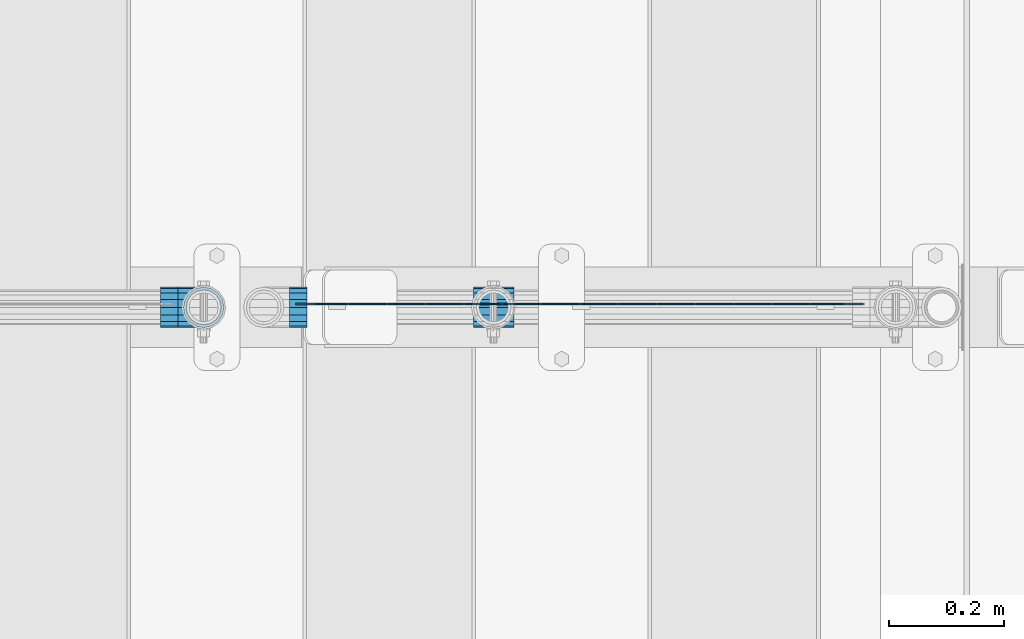
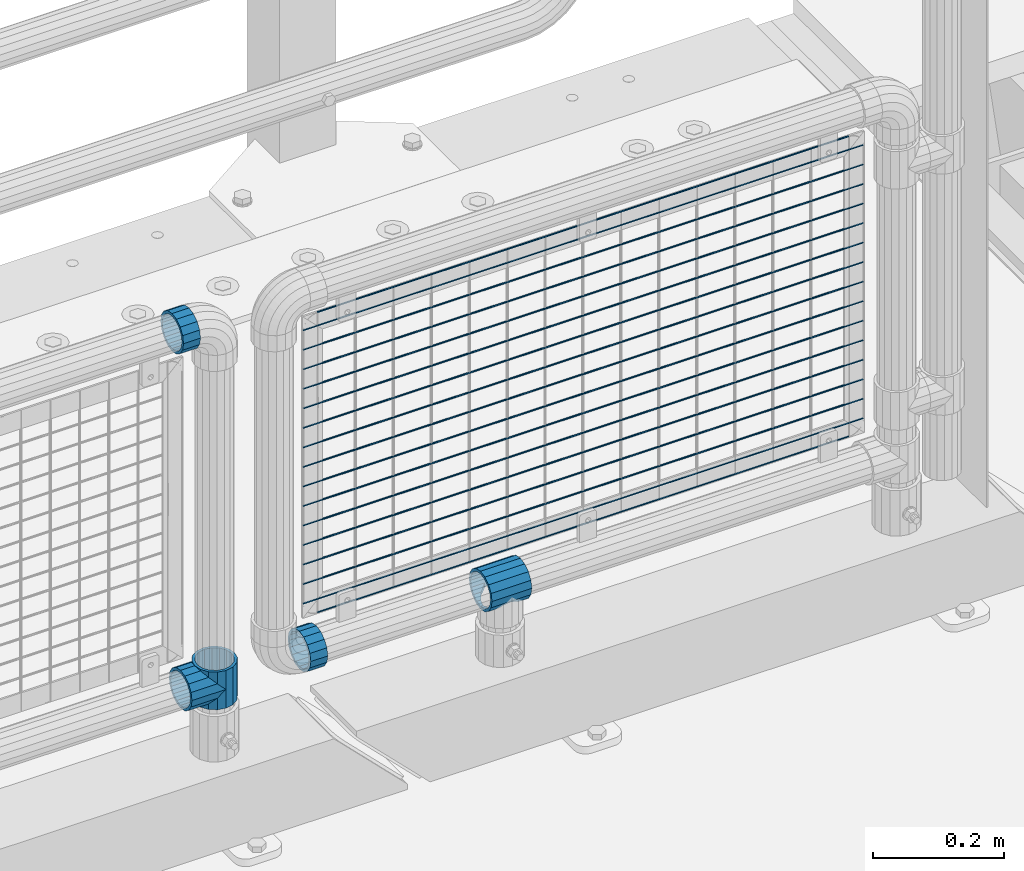
# One storey, part 157 of 240: 22 beams.
"""IFC2X3 building model written with IfcOpenShell, lengths in millimetres."""

from ifc_helpers import new_model, si_unit, frame, origin_with_axes, place, context, subcontext, project, spatial, faceted_brep, material, type_object, element, save


model = new_model("IFC2X3")

# Units and contexts
model_context = context("Model", 3, precision=1e-05, world=origin_with_axes())
body_context = subcontext(model_context, "Body", "Model", "MODEL_VIEW")
ifc_project = project(units=[si_unit("LENGTHUNIT", "METRE", prefix="MILLI"), si_unit("AREAUNIT", "SQUARE_METRE"), si_unit("VOLUMEUNIT", "CUBIC_METRE"), si_unit("MASSUNIT", "GRAM", prefix="KILO"), si_unit("TIMEUNIT", "SECOND"), si_unit("PLANEANGLEUNIT", "RADIAN"), si_unit("SOLIDANGLEUNIT", "STERADIAN"), si_unit("THERMODYNAMICTEMPERATUREUNIT", "DEGREE_CELSIUS"), si_unit("LUMINOUSINTENSITYUNIT", "LUMEN")], contexts=[model_context])

# Site, building, storey
site_placement = place(None, origin_with_axes())
site = spatial("IfcSite", under=ifc_project, at=site_placement, CompositionType="ELEMENT")
building_placement = place(site_placement, origin_with_axes())
building = spatial("IfcBuilding", under=site, at=building_placement, Name="Standard", CompositionType="ELEMENT")
storey_placement = place(building_placement, origin_with_axes())
storey = spatial("IfcBuildingStorey", under=building, at=storey_placement, Name="Undefined", CompositionType="ELEMENT", Elevation=0.0)

# Beams
ifc_material = material(Name="Misc_Undefined")
beam_type_1 = type_object("IfcBeamType", PredefinedType="NOTDEFINED")
beam_1_placement = place(storey_placement, frame((55146.46, 34664.5, 298.169999999999), z_axis=(0.0, 0.0, 1.0), x_axis=(1.0, 0.0, 0.0)))
element("IfcBeam", 1, at=beam_1_placement, inside=storey, type_object=beam_type_1, material=ifc_material, context=body_context, shape_type="Brep", body=[
    faceted_brep([(63.1897438117172, -11.6144421722784, -28.0397438117143), (63.1897438117172, -11.6144421722784, -32.8397438117245), (61.9623795176703, -13.4513226476338, -32.4743655677739), (56.6106908090114, -21.4606908090136, -27.1226768591223), (56.6106908090114, -21.4606908090136, -21.4606908090136), (51.5310424080006, -24.8548033587067, -24.8548033587067), (46.7644421722801, -28.0397438117143, -20.0882031229994), (46.7644421722801, -28.0397438117143, -11.6144421722784), (35.1499999999996, -30.3499999999985, -16.6306603983758), (35.1500000000015, -30.35, 0.0), (23.5355578277191, -28.0397438117143, -20.0882031229994), (23.5355578277191, -28.0397438117143, -11.6144421722784), (18.7689575919987, -24.8548033587067, -24.8548033587067), (13.6893091909879, -21.4606908090136, -27.1226768591223), (13.6893091909879, -21.4606908090136, -21.4606908090136), (8.33762048232455, -13.4513226476338, -32.4743655677739), (7.11025618828211, -11.6144421722784, -32.8397438117245), (7.11025618828211, -11.6144421722784, -28.0397438117143), (4.79999999999961, 0.0, -35.1500000000015), (4.79999999999961, 0.0, -30.3499999999985), (7.11025618828211, 11.6144421722784, -32.8397438117172), (7.11025618828211, 11.6144421722784, -28.0397438117143), (8.33762048232893, 13.4513226476338, -32.4743655677739), (13.6893091909879, 21.4606908090136, -27.1226768591077), (13.6893091909879, 21.4606908090136, -21.4606908090136), (18.7689575919921, 24.8548033587067, -24.8548033587067), (23.5355578277192, 28.0397438117143, -20.0882031229849), (23.5355578277192, 28.0397438117143, -11.6144421722784), (35.1499999999996, 30.3499999999985, -16.6306603983685), (35.1500000000015, 30.35, 0.0), (46.7644421722801, 28.0397438117143, -20.0882031229849), (46.7644421722801, 28.0397438117143, -11.6144421722784), (51.5310424079941, 24.8548033587067, -24.8548033587067), (56.6106908090114, 21.4606908090136, -27.1226768591077), (56.6106908090114, 21.4606908090136, -21.4606908090136), (61.9623795176703, 13.4513226476338, -32.4743655677739), (63.1897438117172, 11.6144421722784, -32.8397438117172), (63.1897438117172, 11.6144421722784, -28.0397438117143), (65.4999999999997, 0.0, -35.1500000000015), (65.4999999999997, 0.0, -30.3499999999985), (0.0, -21.4606908090136, -21.4606908090136), (0.0, -28.0397438117143, -11.6144421722784), (0.0, -11.6144421722784, -28.0397438117143), (0.0, 0.0, -30.3499999999985), (0.0, 11.6144421722784, -28.0397438117143), (0.0, 21.4606908090136, -21.4606908090136), (0.0, 28.0397438117143, -11.6144421722784), (0.0, 30.3499999999985, 0.0), (0.0, 32.4743655677739, -13.4513226476338), (0.0, 35.1500000000015, 0.0), (70.2999999999993, 35.1500000000015, 0.0), (70.2999999999993, 32.4743655677739, -13.4513226476338), (0.0, 32.4743655677739, 13.4513226476338), (70.2999999999993, 32.4743655677739, 13.4513226476338), (0.0, 24.8548033587067, 24.8548033587067), (70.2999999999993, 24.8548033587067, 24.8548033587067), (0.0, 13.4513226476338, 32.4743655677739), (70.2999999999993, 13.4513226476338, 32.4743655677739), (0.0, 0.0, 35.1500000000015), (70.2999999999993, 0.0, 35.1500000000015), (0.0, -13.4513226476338, 32.4743655677739), (70.2999999999993, -13.4513226476338, 32.4743655677739), (0.0, -24.8548033587067, 24.8548033587067), (70.2999999999993, -24.8548033587067, 24.8548033587067), (0.0, -32.4743655677739, 13.4513226476338), (70.2999999999993, -32.4743655677739, 13.4513226476338), (0.0, -35.1500000000015, 0.0), (70.2999999999993, -35.1500000000015, 0.0), (0.0, -32.4743655677739, -13.4513226476338), (70.2999999999993, -32.4743655677739, -13.4513226476338), (0.0, 24.8548033587067, -24.8548033587067), (0.0, 13.4513226476338, -32.4743655677739), (0.0, 0.0, -35.1500000000015), (0.0, -13.4513226476338, -32.4743655677739), (0.0, -24.8548033587067, -24.8548033587067), (0.0, 28.0397438117143, 11.6144421722784), (0.0, 21.4606908090136, 21.4606908090136), (0.0, 11.6144421722784, 28.0397438117143), (0.0, 0.0, 30.3499999999985), (0.0, -11.6144421722784, 28.0397438117143), (0.0, -21.4606908090136, 21.4606908090136), (0.0, -28.0397438117143, 11.6144421722784), (0.0, -30.3499999999985, 0.0), (70.2999999999993, -30.3499999999985, 0.0), (70.2999999999993, -28.0397438117143, -11.6144421722784), (70.2999999999993, -21.4606908090136, -21.4606908090136), (70.2999999999993, -11.6144421722784, -28.0397438117143), (70.2999999999993, 0.0, -30.3499999999985), (70.2999999999993, 21.4606908090136, -21.4606908090136), (70.2999999999993, 28.0397438117143, -11.6144421722784), (70.2999999999993, 11.6144421722784, -28.0397438117143), (70.2999999999993, 30.3499999999985, 0.0), (70.2999999999993, 28.0397438117143, 11.6144421722784), (70.2999999999993, 21.4606908090136, 21.4606908090136), (70.2999999999993, 11.6144421722784, 28.0397438117143), (70.2999999999993, 0.0, 30.3499999999985), (70.2999999999993, -11.6144421722784, 28.0397438117143), (70.2999999999993, -21.4606908090136, 21.4606908090136), (70.2999999999993, -28.0397438117143, 11.6144421722784), (70.2999999999993, -24.8548033587067, -24.8548033587067), (70.2999999999993, -13.4513226476338, -32.4743655677739), (70.2999999999993, 0.0, -35.1500000000015), (70.2999999999993, 13.4513226476338, -32.4743655677739), (70.2999999999993, 24.8548033587067, -24.8548033587067)], [[[0, 1, 2, 3, 4]], [[4, 3, 5, 6, 7]], [[7, 6, 8, 9]], [[9, 8, 10, 11]], [[11, 10, 12, 13, 14]], [[14, 13, 15, 16, 17]], [[17, 16, 18, 19]], [[19, 18, 20, 21]], [[21, 20, 22, 23, 24]], [[24, 23, 25, 26, 27]], [[27, 26, 28, 29]], [[29, 28, 30, 31]], [[31, 30, 32, 33, 34]], [[34, 33, 35, 36, 37]], [[37, 36, 38, 39]], [[39, 38, 1, 0]], [[40, 41, 11, 14]], [[42, 40, 14, 17]], [[43, 42, 17, 19]], [[44, 43, 19, 21]], [[45, 44, 21, 24]], [[46, 45, 24, 27]], [[47, 46, 27, 29]], [[48, 49, 50, 51]], [[49, 52, 53, 50]], [[52, 54, 55, 53]], [[54, 56, 57, 55]], [[56, 58, 59, 57]], [[58, 60, 61, 59]], [[60, 62, 63, 61]], [[62, 64, 65, 63]], [[64, 66, 67, 65]], [[66, 68, 69, 67]], [[64, 62, 60, 58, 56, 54, 52, 49, 48, 70, 71, 72, 73, 74, 68, 66], [41, 40, 42, 43, 44, 45, 46, 47, 75, 76, 77, 78, 79, 80, 81, 82]], [[41, 82, 9, 11]], [[83, 84, 7, 9]], [[84, 85, 4, 7]], [[85, 86, 0, 4]], [[86, 87, 39, 0]], [[88, 89, 31, 34]], [[90, 88, 34, 37]], [[87, 90, 37, 39]], [[89, 91, 29, 31]], [[75, 47, 29, 91, 92]], [[76, 75, 92, 93]], [[77, 76, 93, 94]], [[78, 77, 94, 95]], [[79, 78, 95, 96]], [[80, 79, 96, 97]], [[81, 80, 97, 98]], [[9, 82, 81, 98, 83]], [[99, 100, 101, 102, 103, 51, 50, 53, 55, 57, 59, 61, 63, 65, 67, 69], [97, 96, 95, 94, 93, 92, 91, 89, 88, 90, 87, 86, 85, 84, 83, 98]], [[102, 101, 38, 36, 35]], [[103, 102, 35, 33, 32]], [[25, 70, 48, 51, 103, 32, 30, 28, 26]], [[22, 71, 70, 25, 23]], [[18, 72, 71, 22, 20]], [[73, 72, 18, 16, 15]], [[74, 73, 15, 13, 12]], [[5, 99, 69, 68, 74, 12, 10, 8, 6]], [[2, 100, 99, 5, 3]], [[38, 101, 100, 2, 1]]]),
])
beam_2_placement = place(storey_placement, frame((54677.0, 34664.5, 298.670000000001), z_axis=(0.0, 1.0, 0.0), x_axis=(-1.0, 0.0, 0.0)))
element("IfcBeam", 2, at=beam_2_placement, inside=storey, type_object=beam_type_1, material=ifc_material, context=body_context, shape_type="Brep", body=[
    faceted_brep([(0.0, 0.0, -35.1500000000015), (13.4513226476338, -13.4513226476329, -32.4743655677739), (13.4513226476338, 13.4513226476329, -32.4743655677739), (27.1226768591005, -21.4606908090117, 21.4606908090136), (32.4743655677739, -26.8123795176712, 13.4513226476338), (32.4743655677739, -32.4743655677717, 13.4513226476338), (24.8548033587067, -24.8548033587072, 24.8548033587067), (24.8548033587067, -16.3810424080078, 24.8548033587067), (32.8397438117099, -28.0397438117175, 11.6144421722784), (35.1500000000015, -30.35, 0.0), (35.1500000000015, -35.15, 0.0), (32.4743655677739, -26.8123795176712, -13.4513226476338), (32.4743655677739, -32.4743655677717, -13.4513226476338), (32.8397438117172, -28.0397438117175, -11.6144421722784), (24.8548033587067, -16.3810424079947, -24.8548033587067), (24.8548033587067, -24.8548033587072, -24.8548033587067), (27.1226768591223, -21.4606908090117, -21.4606908090136), (20.0882031229994, -11.6144421722805, -28.0397438117143), (16.6306603983758, 0.0, -30.3499999999985), (20.0882031229994, 11.6144421722805, -28.0397438117143), (24.8548033587067, 16.3810424080013, -24.8548033587067), (24.8548033587067, 24.8548033587072, -24.8548033587067), (27.1226768591223, 21.4606908090117, -21.4606908090136), (32.4743655677739, 26.8123795176712, -13.4513226476338), (32.4743655677739, 32.4743655677717, -13.4513226476338), (32.8397438117172, 28.0397438117175, -11.6144421722784), (35.1500000000015, 30.35, 0.0), (35.1500000000015, 35.15, 0.0), (32.8397438117099, 28.0397438117175, 11.6144421722784), (32.4743655677739, 26.8123795176755, 13.4513226476338), (32.4743655677739, 32.4743655677717, 13.4513226476338), (27.1226768591005, 21.4606908090117, 21.4606908090136), (24.8548033587067, 16.3810424080013, 24.8548033587067), (24.8548033587067, 24.8548033587072, 24.8548033587067), (0.0, 0.0, 35.1500000000015), (13.4513226476338, 13.4513226476329, 32.4743655677739), (13.4513226476338, -13.4513226476329, 32.4743655677739), (20.0882031229849, 11.6144421722805, 28.0397438117143), (16.6306603983685, 0.0, 30.3499999999985), (20.0882031229849, -11.6144421722805, 28.0397438117143), (60.1500000000015, -35.15, 0.0), (60.1500000000015, -32.4743655677717, 13.4513226476338), (60.1500000000015, -24.8548033587072, 24.8548033587067), (60.1500000000015, -13.4513226476329, 32.4743655677739), (60.1500000000015, 0.0, 35.1500000000015), (60.1500000000015, -24.8548033587072, -24.8548033587067), (60.1500000000015, -32.4743655677717, -13.4513226476338), (60.1500000000015, -13.4513226476329, -32.4743655677739), (60.1500000000015, 0.0, -35.1500000000015), (60.1500000000015, 13.4513226476329, -32.4743655677739), (60.1500000000015, 24.8548033587072, -24.8548033587067), (60.1500000000015, 32.4743655677717, -13.4513226476338), (60.1500000000015, 35.15, 0.0), (60.1500000000015, 32.4743655677717, 13.4513226476338), (60.1500000000015, 24.8548033587072, 24.8548033587067), (60.1500000000015, 13.4513226476329, 32.4743655677739), (60.1500000000015, -21.4606908090117, 21.4606908090136), (60.1500000000015, -11.6144421722805, 28.0397438117143), (60.1500000000015, 0.0, 30.3499999999985), (60.1500000000015, 11.6144421722805, 28.0397438117143), (60.1500000000015, 21.4606908090117, 21.4606908090136), (60.1500000000015, 28.0397438117175, 11.6144421722784), (60.1500000000015, 30.35, 0.0), (60.1500000000015, 28.0397438117175, -11.6144421722784), (60.1500000000015, 21.4606908090117, -21.4606908090136), (60.1500000000015, 11.6144421722805, -28.0397438117143), (60.1500000000015, 0.0, -30.3499999999985), (60.1500000000015, -11.6144421722805, -28.0397438117143), (60.1500000000015, -21.4606908090117, -21.4606908090136), (60.1500000000015, -28.0397438117175, -11.6144421722784), (60.1500000000015, -30.35, 0.0), (60.1500000000015, -28.0397438117175, 11.6144421722784)], [[[0, 1, 2]], [[3, 4, 5, 6, 7]], [[8, 9, 10, 5, 4]], [[11, 12, 10, 9, 13]], [[14, 15, 12, 11, 16]], [[2, 1, 15, 14, 17, 18, 19, 20, 21]], [[21, 20, 22, 23, 24]], [[24, 23, 25, 26, 27]], [[27, 26, 28, 29, 30]], [[30, 29, 31, 32, 33]], [[34, 35, 36]], [[33, 32, 37, 38, 39, 7, 6, 36, 35]], [[40, 41, 5, 10]], [[41, 42, 6, 5]], [[42, 43, 36, 6]], [[43, 44, 34, 36]], [[45, 46, 12, 15]], [[47, 45, 15, 1]], [[48, 47, 1, 0]], [[49, 48, 0, 2]], [[50, 49, 2, 21]], [[51, 50, 21, 24]], [[52, 51, 24, 27]], [[53, 52, 27, 30]], [[54, 53, 30, 33]], [[55, 54, 33, 35]], [[44, 55, 35, 34]], [[46, 40, 10, 12]], [[45, 47, 48, 49, 50, 51, 52, 53, 54, 55, 44, 43, 42, 41, 40, 46], [56, 57, 58, 59, 60, 61, 62, 63, 64, 65, 66, 67, 68, 69, 70, 71]], [[59, 58, 38, 37]], [[31, 60, 59, 37, 32]], [[28, 61, 60, 31, 29]], [[62, 61, 28, 26]], [[63, 62, 26, 25]], [[64, 63, 25, 23, 22]], [[65, 64, 22, 20, 19]], [[66, 65, 19, 18]], [[67, 66, 18, 17]], [[16, 68, 67, 17, 14]], [[13, 69, 68, 16, 11]], [[70, 69, 13, 9]], [[71, 70, 9, 8]], [[56, 71, 8, 4, 3]], [[57, 56, 3, 7, 39]], [[58, 57, 39, 38]]]),
])
beam_3_placement = place(storey_placement, frame((54677.0, 34664.5, 333.820000000001), z_axis=(1.0, 0.0, 0.0), x_axis=(0.0, 0.0, -1.0)))
element("IfcBeam", 3, at=beam_3_placement, inside=storey, type_object=beam_type_1, material=ifc_material, context=body_context, shape_type="Brep", body=[
    faceted_brep([(46.7644421722801, 28.0397438117143, -11.6144421722784), (46.7644421722801, 28.0397438117143, -20.0882031229849), (51.5310424079941, 24.8548033587067, -24.8548033587067), (56.6106908090114, 21.4606908090136, -27.1226768591077), (56.6106908090114, 21.4606908090136, -21.4606908090136), (61.9623795176703, 13.4513226476338, -32.4743655677739), (63.1897438117172, 11.6144421722784, -32.8397438117172), (63.1897438117172, 11.6144421722784, -28.0397438117143), (65.4999999999997, 0.0, -35.1500000000015), (65.4999999999997, 0.0, -30.3499999999985), (63.1897438117172, -11.6144421722784, -32.8397438117245), (63.1897438117172, -11.6144421722784, -28.0397438117143), (61.9623795176703, -13.4513226476338, -32.4743655677739), (56.6106908090114, -21.4606908090136, -27.1226768591223), (56.6106908090114, -21.4606908090136, -21.4606908090136), (51.5310424080006, -24.8548033587067, -24.8548033587067), (46.7644421722801, -28.0397438117143, -20.0882031229994), (46.7644421722801, -28.0397438117143, -11.6144421722784), (35.1499999999996, -30.3499999999985, -16.6306603983758), (35.1500000000015, -30.35, 0.0), (23.5355578277191, -28.0397438117143, -20.0882031229994), (23.5355578277191, -28.0397438117143, -11.6144421722784), (18.7689575919987, -24.8548033587067, -24.8548033587067), (13.6893091909879, -21.4606908090136, -27.1226768591223), (13.6893091909879, -21.4606908090136, -21.4606908090136), (8.33762048232455, -13.4513226476338, -32.4743655677739), (7.11025618828211, -11.6144421722784, -32.8397438117245), (7.11025618828211, -11.6144421722784, -28.0397438117143), (4.79999999999961, 0.0, -35.1500000000015), (4.79999999999961, 0.0, -30.3499999999985), (7.11025618828211, 11.6144421722784, -32.8397438117172), (7.11025618828211, 11.6144421722784, -28.0397438117143), (8.33762048232893, 13.4513226476338, -32.4743655677739), (13.6893091909879, 21.4606908090136, -27.1226768591077), (13.6893091909879, 21.4606908090136, -21.4606908090136), (18.7689575919921, 24.8548033587067, -24.8548033587067), (23.5355578277192, 28.0397438117143, -20.0882031229849), (23.5355578277192, 28.0397438117143, -11.6144421722784), (35.1499999999996, 30.3499999999985, -16.6306603983685), (35.1500000000015, 30.35, 0.0), (0.0, 32.4743655677739, -13.4513226476338), (0.0, 35.1500000000015, 0.0), (70.2999999999993, 35.1500000000015, 0.0), (70.2999999999993, 32.4743655677739, -13.4513226476338), (0.0, 32.4743655677739, 13.4513226476338), (70.2999999999993, 32.4743655677739, 13.4513226476338), (0.0, 24.8548033587067, 24.8548033587067), (70.2999999999993, 24.8548033587067, 24.8548033587067), (0.0, 13.4513226476338, 32.4743655677739), (70.2999999999993, 13.4513226476338, 32.4743655677739), (0.0, 0.0, 35.1500000000015), (70.2999999999993, 0.0, 35.1500000000015), (0.0, -13.4513226476338, 32.4743655677739), (70.2999999999993, -13.4513226476338, 32.4743655677739), (0.0, -24.8548033587067, 24.8548033587067), (70.2999999999993, -24.8548033587067, 24.8548033587067), (0.0, -32.4743655677739, 13.4513226476338), (70.2999999999993, -32.4743655677739, 13.4513226476338), (0.0, -35.1500000000015, 0.0), (70.2999999999993, -35.1500000000015, 0.0), (70.2999999999993, -30.3499999999985, 0.0), (70.2999999999993, -28.0397438117143, -11.6144421722784), (70.2999999999993, -21.4606908090136, -21.4606908090136), (70.2999999999993, -11.6144421722784, -28.0397438117143), (70.2999999999993, 0.0, -30.3499999999985), (70.2999999999993, 11.6144421722784, -28.0397438117143), (70.2999999999993, 21.4606908090136, -21.4606908090136), (70.2999999999993, 28.0397438117143, -11.6144421722784), (0.0, -28.0397438117143, -11.6144421722784), (0.0, -30.3499999999985, 0.0), (0.0, -21.4606908090136, -21.4606908090136), (0.0, -11.6144421722784, -28.0397438117143), (0.0, 0.0, -30.3499999999985), (0.0, 11.6144421722784, -28.0397438117143), (0.0, 21.4606908090136, -21.4606908090136), (0.0, 28.0397438117143, -11.6144421722784), (0.0, 30.3499999999985, 0.0), (70.2999999999993, 30.3499999999985, 0.0), (0.0, 28.0397438117143, 11.6144421722784), (70.2999999999993, 28.0397438117143, 11.6144421722784), (0.0, 21.4606908090136, 21.4606908090136), (70.2999999999993, 21.4606908090136, 21.4606908090136), (0.0, 11.6144421722784, 28.0397438117143), (70.2999999999993, 11.6144421722784, 28.0397438117143), (0.0, 0.0, 30.3499999999985), (70.2999999999993, 0.0, 30.3499999999985), (0.0, -11.6144421722784, 28.0397438117143), (70.2999999999993, -11.6144421722784, 28.0397438117143), (0.0, -21.4606908090136, 21.4606908090136), (70.2999999999993, -21.4606908090136, 21.4606908090136), (0.0, -28.0397438117143, 11.6144421722784), (70.2999999999993, -28.0397438117143, 11.6144421722784), (70.2999999999993, -24.8548033587067, -24.8548033587067), (70.2999999999993, -13.4513226476338, -32.4743655677739), (70.2999999999993, 0.0, -35.1500000000015), (70.2999999999993, 13.4513226476338, -32.4743655677739), (70.2999999999993, 24.8548033587067, -24.8548033587067), (70.2999999999993, -32.4743655677739, -13.4513226476338), (0.0, -32.4743655677739, -13.4513226476338), (0.0, 24.8548033587067, -24.8548033587067), (0.0, 13.4513226476338, -32.4743655677739), (0.0, 0.0, -35.1500000000015), (0.0, -13.4513226476338, -32.4743655677739), (0.0, -24.8548033587067, -24.8548033587067)], [[[0, 1, 2, 3, 4]], [[4, 3, 5, 6, 7]], [[7, 6, 8, 9]], [[9, 8, 10, 11]], [[11, 10, 12, 13, 14]], [[14, 13, 15, 16, 17]], [[17, 16, 18, 19]], [[19, 18, 20, 21]], [[21, 20, 22, 23, 24]], [[24, 23, 25, 26, 27]], [[27, 26, 28, 29]], [[29, 28, 30, 31]], [[31, 30, 32, 33, 34]], [[34, 33, 35, 36, 37]], [[37, 36, 38, 39]], [[39, 38, 1, 0]], [[40, 41, 42, 43]], [[41, 44, 45, 42]], [[44, 46, 47, 45]], [[46, 48, 49, 47]], [[48, 50, 51, 49]], [[50, 52, 53, 51]], [[52, 54, 55, 53]], [[54, 56, 57, 55]], [[56, 58, 59, 57]], [[60, 61, 17, 19]], [[61, 62, 14, 17]], [[62, 63, 11, 14]], [[63, 64, 9, 11]], [[64, 65, 7, 9]], [[65, 66, 4, 7]], [[66, 67, 0, 4]], [[68, 69, 19, 21]], [[70, 68, 21, 24]], [[71, 70, 24, 27]], [[72, 71, 27, 29]], [[73, 72, 29, 31]], [[74, 73, 31, 34]], [[75, 74, 34, 37]], [[76, 75, 37, 39]], [[67, 77, 39, 0]], [[78, 76, 39, 77, 79]], [[80, 78, 79, 81]], [[82, 80, 81, 83]], [[84, 82, 83, 85]], [[86, 84, 85, 87]], [[88, 86, 87, 89]], [[90, 88, 89, 91]], [[19, 69, 90, 91, 60]], [[92, 93, 94, 95, 96, 43, 42, 45, 47, 49, 51, 53, 55, 57, 59, 97], [89, 87, 85, 83, 81, 79, 77, 67, 66, 65, 64, 63, 62, 61, 60, 91]], [[58, 98, 97, 59]], [[56, 54, 52, 50, 48, 46, 44, 41, 40, 99, 100, 101, 102, 103, 98, 58], [68, 70, 71, 72, 73, 74, 75, 76, 78, 80, 82, 84, 86, 88, 90, 69]], [[32, 100, 99, 35, 33]], [[28, 101, 100, 32, 30]], [[102, 101, 28, 26, 25]], [[103, 102, 25, 23, 22]], [[15, 92, 97, 98, 103, 22, 20, 18, 16]], [[12, 93, 92, 15, 13]], [[8, 94, 93, 12, 10]], [[95, 94, 8, 6, 5]], [[96, 95, 5, 3, 2]], [[35, 99, 40, 43, 96, 2, 1, 38, 36]]]),
])
beam_4_placement = place(storey_placement, frame((54632.0, 34664.5, 969.85), z_axis=(0.0, 0.0, 1.0), x_axis=(-1.0, 0.0, 0.0)))
element("IfcBeam", 4, at=beam_4_placement, inside=storey, type_object=beam_type_1, material=ifc_material, context=body_context, shape_type="Brep", body=[
    faceted_brep([(0.0, -30.3499999999985, 0.0), (0.0, -28.0397438117143, 11.6144421722784), (30.0, -28.0397438117143, 11.6144421722805), (30.0, -30.3499999999985, 0.0), (0.0, -21.4606908090136, 21.4606908090136), (30.0, -21.4606908090136, 21.4606908090117), (0.0, -11.6144421722784, 28.0397438117143), (30.0, -11.6144421722784, 28.0397438117176), (0.0, 0.0, 30.3499999999985), (30.0, 0.0, 30.35), (0.0, 11.6144421722784, 28.0397438117143), (30.0, 11.6144421722784, 28.0397438117176), (0.0, 21.4606908090136, 21.4606908090136), (30.0, 21.4606908090136, 21.4606908090117), (0.0, 28.0397438117143, 11.6144421722784), (30.0, 28.0397438117143, 11.6144421722805), (0.0, 30.3499999999985, 0.0), (30.0, 30.3499999999985, 0.0), (0.0, 28.0397438117143, -11.6144421722784), (30.0, 28.0397438117143, -11.6144421722805), (0.0, 21.4606908090136, -21.4606908090136), (30.0, 21.4606908090136, -21.4606908090117), (0.0, 11.6144421722784, -28.0397438117143), (30.0, 11.6144421722784, -28.0397438117176), (0.0, 0.0, -30.3499999999985), (30.0, 0.0, -30.35), (0.0, -11.6144421722784, -28.0397438117143), (30.0, -11.6144421722784, -28.0397438117176), (0.0, -21.4606908090136, -21.4606908090136), (30.0, -21.4606908090136, -21.4606908090117), (0.0, -28.0397438117143, -11.6144421722784), (30.0, -28.0397438117143, -11.6144421722805), (0.0, -35.1500000000015, 0.0), (0.0, -32.4743655677739, -13.4513226476338), (30.0, -32.4743655677739, -13.4513226476329), (30.0, -35.1500000000015, 0.0), (0.0, -24.8548033587067, -24.8548033587067), (30.0, -24.8548033587067, -24.8548033587072), (0.0, -13.4513226476338, -32.4743655677739), (30.0, -13.4513226476338, -32.4743655677718), (0.0, 0.0, -35.1500000000015), (30.0, 0.0, -35.15), (0.0, 13.4513226476338, -32.4743655677739), (30.0, 13.4513226476338, -32.4743655677718), (0.0, 24.8548033587067, -24.8548033587067), (30.0, 24.8548033587067, -24.8548033587072), (0.0, 32.4743655677739, -13.4513226476338), (30.0, 32.4743655677739, -13.4513226476329), (0.0, 35.1500000000015, 0.0), (30.0, 35.1500000000015, 0.0), (0.0, 32.4743655677739, 13.4513226476338), (30.0, 32.4743655677739, 13.4513226476329), (0.0, 24.8548033587067, 24.8548033587067), (30.0, 24.8548033587067, 24.8548033587072), (0.0, 13.4513226476338, 32.4743655677739), (30.0, 13.4513226476338, 32.4743655677718), (0.0, 0.0, 35.1500000000015), (30.0, 0.0, 35.15), (0.0, -13.4513226476338, 32.4743655677739), (30.0, -13.4513226476338, 32.4743655677718), (0.0, -24.8548033587067, 24.8548033587067), (30.0, -24.8548033587067, 24.8548033587072), (0.0, -32.4743655677739, 13.4513226476338), (30.0, -32.4743655677739, 13.4513226476329)], [[[0, 1, 2, 3]], [[1, 4, 5, 2]], [[4, 6, 7, 5]], [[6, 8, 9, 7]], [[8, 10, 11, 9]], [[10, 12, 13, 11]], [[12, 14, 15, 13]], [[14, 16, 17, 15]], [[16, 18, 19, 17]], [[18, 20, 21, 19]], [[20, 22, 23, 21]], [[22, 24, 25, 23]], [[24, 26, 27, 25]], [[26, 28, 29, 27]], [[28, 30, 31, 29]], [[30, 0, 3, 31]], [[32, 33, 34, 35]], [[33, 36, 37, 34]], [[36, 38, 39, 37]], [[38, 40, 41, 39]], [[40, 42, 43, 41]], [[42, 44, 45, 43]], [[44, 46, 47, 45]], [[46, 48, 49, 47]], [[48, 50, 51, 49]], [[50, 52, 53, 51]], [[52, 54, 55, 53]], [[54, 56, 57, 55]], [[56, 58, 59, 57]], [[58, 60, 61, 59]], [[60, 62, 63, 61]], [[62, 32, 35, 63]], [[37, 39, 41, 43, 45, 47, 49, 51, 53, 55, 57, 59, 61, 63, 35, 34], [5, 7, 9, 11, 13, 15, 17, 19, 21, 23, 25, 27, 29, 31, 3, 2]], [[62, 60, 58, 56, 54, 52, 50, 48, 46, 44, 42, 40, 38, 36, 33, 32], [30, 28, 26, 24, 22, 20, 18, 16, 14, 12, 10, 8, 6, 4, 1, 0]]]),
])
beam_5_placement = place(storey_placement, frame((54826.61, 34664.5, 298.170000000001), z_axis=(0.0, 0.0, -1.0), x_axis=(1.0, 0.0, 0.0)))
element("IfcBeam", 5, at=beam_5_placement, inside=storey, type_object=beam_type_1, material=ifc_material, context=body_context, shape_type="Brep", body=[
    faceted_brep([(0.0, -30.3499999999985, 0.0), (0.0, -28.0397438117143, 11.6144421722784), (30.0, -28.0397438117143, 11.6144421722805), (30.0, -30.3499999999985, 0.0), (0.0, -21.4606908090136, 21.4606908090136), (30.0, -21.4606908090136, 21.4606908090117), (0.0, -11.6144421722784, 28.0397438117143), (30.0, -11.6144421722784, 28.0397438117176), (0.0, 0.0, 30.3499999999985), (30.0, 0.0, 30.35), (0.0, 11.6144421722784, 28.0397438117143), (30.0, 11.6144421722784, 28.0397438117176), (0.0, 21.4606908090136, 21.4606908090136), (30.0, 21.4606908090136, 21.4606908090117), (0.0, 28.0397438117143, 11.6144421722784), (30.0, 28.0397438117143, 11.6144421722805), (0.0, 30.3499999999985, 0.0), (30.0, 30.3499999999985, 0.0), (0.0, 28.0397438117143, -11.6144421722784), (30.0, 28.0397438117143, -11.6144421722805), (0.0, 21.4606908090136, -21.4606908090136), (30.0, 21.4606908090136, -21.4606908090117), (0.0, 11.6144421722784, -28.0397438117143), (30.0, 11.6144421722784, -28.0397438117176), (0.0, 0.0, -30.3499999999985), (30.0, 0.0, -30.35), (0.0, -11.6144421722784, -28.0397438117143), (30.0, -11.6144421722784, -28.0397438117176), (0.0, -21.4606908090136, -21.4606908090136), (30.0, -21.4606908090136, -21.4606908090117), (0.0, -28.0397438117143, -11.6144421722784), (30.0, -28.0397438117143, -11.6144421722805), (0.0, -35.1500000000015, 0.0), (0.0, -32.4743655677739, -13.4513226476338), (30.0, -32.4743655677739, -13.4513226476329), (30.0, -35.1500000000015, 0.0), (0.0, -24.8548033587067, -24.8548033587067), (30.0, -24.8548033587067, -24.8548033587072), (0.0, -13.4513226476338, -32.4743655677739), (30.0, -13.4513226476338, -32.4743655677718), (0.0, 0.0, -35.1500000000015), (30.0, 0.0, -35.15), (0.0, 13.4513226476338, -32.4743655677739), (30.0, 13.4513226476338, -32.4743655677718), (0.0, 24.8548033587067, -24.8548033587067), (30.0, 24.8548033587067, -24.8548033587072), (0.0, 32.4743655677739, -13.4513226476338), (30.0, 32.4743655677739, -13.4513226476329), (0.0, 35.1500000000015, 0.0), (30.0, 35.1500000000015, 0.0), (0.0, 32.4743655677739, 13.4513226476338), (30.0, 32.4743655677739, 13.4513226476329), (0.0, 24.8548033587067, 24.8548033587067), (30.0, 24.8548033587067, 24.8548033587072), (0.0, 13.4513226476338, 32.4743655677739), (30.0, 13.4513226476338, 32.4743655677718), (0.0, 0.0, 35.1500000000015), (30.0, 0.0, 35.15), (0.0, -13.4513226476338, 32.4743655677739), (30.0, -13.4513226476338, 32.4743655677718), (0.0, -24.8548033587067, 24.8548033587067), (30.0, -24.8548033587067, 24.8548033587072), (0.0, -32.4743655677739, 13.4513226476338), (30.0, -32.4743655677739, 13.4513226476329)], [[[0, 1, 2, 3]], [[1, 4, 5, 2]], [[4, 6, 7, 5]], [[6, 8, 9, 7]], [[8, 10, 11, 9]], [[10, 12, 13, 11]], [[12, 14, 15, 13]], [[14, 16, 17, 15]], [[16, 18, 19, 17]], [[18, 20, 21, 19]], [[20, 22, 23, 21]], [[22, 24, 25, 23]], [[24, 26, 27, 25]], [[26, 28, 29, 27]], [[28, 30, 31, 29]], [[30, 0, 3, 31]], [[32, 33, 34, 35]], [[33, 36, 37, 34]], [[36, 38, 39, 37]], [[38, 40, 41, 39]], [[40, 42, 43, 41]], [[42, 44, 45, 43]], [[44, 46, 47, 45]], [[46, 48, 49, 47]], [[48, 50, 51, 49]], [[50, 52, 53, 51]], [[52, 54, 55, 53]], [[54, 56, 57, 55]], [[56, 58, 59, 57]], [[58, 60, 61, 59]], [[60, 62, 63, 61]], [[62, 32, 35, 63]], [[37, 39, 41, 43, 45, 47, 49, 51, 53, 55, 57, 59, 61, 63, 35, 34], [5, 7, 9, 11, 13, 15, 17, 19, 21, 23, 25, 27, 29, 31, 3, 2]], [[62, 60, 58, 56, 54, 52, 50, 48, 46, 44, 42, 40, 38, 36, 33, 32], [30, 28, 26, 24, 22, 20, 18, 16, 14, 12, 10, 8, 6, 4, 1, 0]]]),
])
beam_type_2 = type_object("IfcBeamType", Name="D3", PredefinedType="NOTDEFINED")
for number, where, z_axis, x_axis in (
    (6, (54836.61, 34670.4999883346, 633.023), (0.0, 0.0, 1.0), (1.0, 0.0, 0.0)),
    (7, (54836.61, 34670.4999883385, 815.168), (0.0, 0.0, 1.0), (1.0, 0.0, 0.0)),
    (8, (54836.61, 34670.4999883354, 669.452), (0.0, 0.0, 1.0), (1.0, 0.0, 0.0)),
    (9, (54836.61, 34670.4999883338, 596.594000000001), (0.0, 0.0, 1.0), (1.0, 0.0, 0.0)),
    (10, (54836.61, 34670.4999883331, 560.165), (0.0, 0.0, 1.0), (1.0, 0.0, 0.0)),
    (11, (54836.61, 34670.4999883377, 778.739), (0.0, 0.0, 1.0), (1.0, 0.0, 0.0)),
    (12, (54836.61, 34670.4999883323, 523.736), (0.0, 0.0, 1.0), (1.0, 0.0, 0.0)),
    (13, (54836.61, 34670.4999883392, 851.597), (0.0, 0.0, 1.0), (1.0, 0.0, 0.0)),
    (14, (54836.61, 34670.4999883315, 487.307), (0.0, 0.0, 1.0), (1.0, 0.0, 0.0)),
    (15, (54836.61, 34670.4999883361, 705.881), (0.0, 0.0, 1.0), (1.0, 0.0, 0.0)),
    (16, (54836.61, 34670.4999883308, 450.878), (0.0, 0.0, 1.0), (1.0, 0.0, 0.0)),
    (17, (54836.61, 34670.49998834, 888.026), (0.0, 0.0, 1.0), (1.0, 0.0, 0.0)),
    (18, (54836.61, 34670.4999883369, 742.31), (0.0, 0.0, 1.0), (1.0, 0.0, 0.0)),
    (19, (54836.61, 34670.49998833, 414.449), (0.0, 0.0, 1.0), (1.0, 0.0, 0.0)),
):
    element("IfcBeam", number, at=place(storey_placement, frame(where, z_axis=z_axis, x_axis=x_axis)), inside=storey, type_object=beam_type_2, material=ifc_material, ObjectType="D3", context=body_context, shape_type="Brep", body=[
        faceted_brep([(-7.27595761418343e-12, -1.49999999999272, 0.0), (-7.27595761418343e-12, -0.749999999992724, -1.29903810567669), (988.390000000276, -0.749999999992724, -1.29903810567669), (988.390000000276, -1.49999999999272, 0.0), (0.0, 0.750000000007276, -1.29903810567669), (988.390000000283, 0.750000000007276, -1.29903810567669), (0.0, 1.50000000000728, 0.0), (988.390000000283, 1.50000000000728, 0.0), (0.0, 0.750000000007276, 1.29903810567669), (988.390000000283, 0.750000000007276, 1.29903810567669), (-7.27595761418343e-12, -0.749999999992724, 1.29903810567669), (988.390000000276, -0.749999999992724, 1.29903810567669)], [[[0, 1, 2, 3]], [[1, 4, 5, 2]], [[4, 6, 7, 5]], [[6, 8, 9, 7]], [[8, 10, 11, 9]], [[10, 0, 3, 11]], [[5, 7, 9, 11, 3, 2]], [[10, 8, 6, 4, 1, 0]]]),
    ])
beam_6_placement = place(storey_placement, frame((54861.61, 34670.4999830243, 353.02), z_axis=(0.0, 0.0, 1.0), x_axis=(1.0, 0.0, 0.0)))
element("IfcBeam", 20, at=beam_6_placement, inside=storey, type_object=beam_type_2, material=ifc_material, ObjectType="D3", context=body_context, shape_type="Brep", body=[
    faceted_brep([(-7.27595761418343e-12, -1.49999999999272, 0.0), (-7.27595761418343e-12, -0.749999999992724, -1.29903810567669), (938.390000000138, -0.75, -1.29903810567669), (938.390000000138, -1.5, 0.0), (0.0, 0.750000000007276, -1.29903810567669), (938.390000000145, 0.75, -1.29903810567663), (0.0, 1.50000000000728, 0.0), (938.390000000145, 1.5, 0.0), (0.0, 0.750000000007276, 1.29903810567669), (938.390000000145, 0.75, 1.29903810567669), (-7.27595761418343e-12, -0.749999999992724, 1.29903810567669), (938.390000000138, -0.75, 1.29903810567669)], [[[0, 1, 2, 3]], [[1, 4, 5, 2]], [[4, 6, 7, 5]], [[6, 8, 9, 7]], [[8, 10, 11, 9]], [[10, 0, 3, 11]], [[5, 7, 9, 11, 3, 2]], [[10, 8, 6, 4, 1, 0]]]),
])
beam_7_placement = place(storey_placement, frame((54836.61, 34670.4999883292, 378.02), z_axis=(0.0, 0.0, 1.0), x_axis=(1.0, 0.0, 0.0)))
element("IfcBeam", 21, at=beam_7_placement, inside=storey, type_object=beam_type_2, material=ifc_material, ObjectType="D3", context=body_context, shape_type="Brep", body=[
    faceted_brep([(-7.27595761418343e-12, -1.49999999999272, 0.0), (-7.27595761418343e-12, -0.749999999992724, -1.29903810567669), (988.390000000276, -0.749999999992724, -1.29903810567669), (988.390000000276, -1.49999999999272, 0.0), (0.0, 0.750000000007276, -1.29903810567669), (988.390000000283, 0.750000000007276, -1.29903810567669), (0.0, 1.50000000000728, 0.0), (988.390000000283, 1.50000000000728, 0.0), (0.0, 0.750000000007276, 1.29903810567669), (988.390000000283, 0.750000000007276, 1.29903810567669), (-7.27595761418343e-12, -0.749999999992724, 1.29903810567669), (988.390000000276, -0.749999999992724, 1.29903810567669)], [[[0, 1, 2, 3]], [[1, 4, 5, 2]], [[4, 6, 7, 5]], [[6, 8, 9, 7]], [[8, 10, 11, 9]], [[10, 0, 3, 11]], [[5, 7, 9, 11, 3, 2]], [[10, 8, 6, 4, 1, 0]]]),
])
beam_8_placement = place(storey_placement, frame((54861.61, 34670.49998304, 913.02), z_axis=(0.0, 0.0, 1.0), x_axis=(1.0, 0.0, 0.0)))
element("IfcBeam", 22, at=beam_8_placement, inside=storey, type_object=beam_type_2, material=ifc_material, ObjectType="D3", context=body_context, shape_type="Brep", body=[
    faceted_brep([(-7.27595761418343e-12, -1.49999999999272, 0.0), (-7.27595761418343e-12, -0.749999999992724, -1.29903810567669), (938.390000000138, -0.75, -1.29903810567669), (938.390000000138, -1.5, 0.0), (0.0, 0.750000000007276, -1.29903810567669), (938.390000000145, 0.75, -1.29903810567663), (0.0, 1.50000000000728, 0.0), (938.390000000145, 1.5, 0.0), (0.0, 0.750000000007276, 1.29903810567669), (938.390000000145, 0.75, 1.29903810567669), (-7.27595761418343e-12, -0.749999999992724, 1.29903810567669), (938.390000000138, -0.75, 1.29903810567669)], [[[0, 1, 2, 3]], [[1, 4, 5, 2]], [[4, 6, 7, 5]], [[6, 8, 9, 7]], [[8, 10, 11, 9]], [[10, 0, 3, 11]], [[5, 7, 9, 11, 3, 2]], [[10, 8, 6, 4, 1, 0]]]),
])

save(model, "model.ifc")
